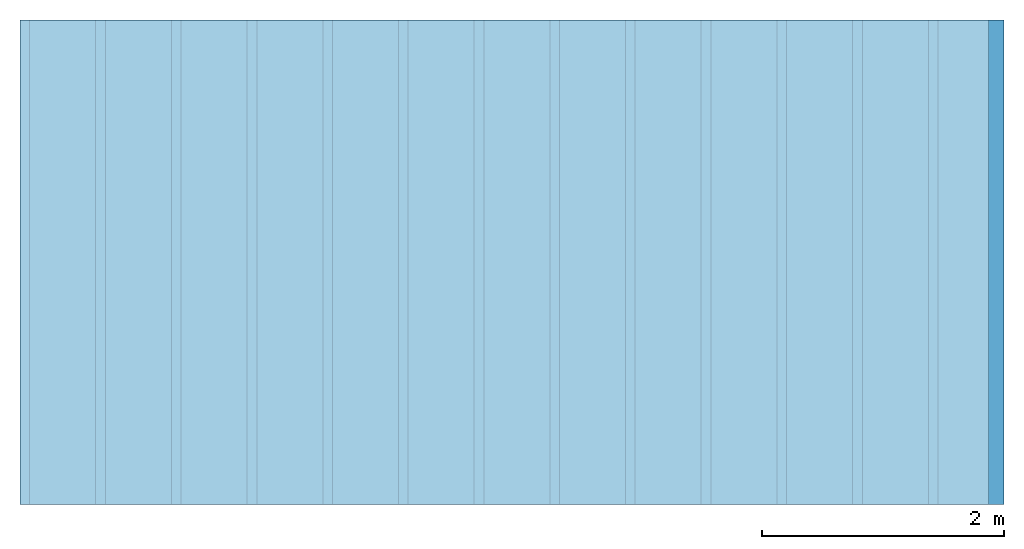
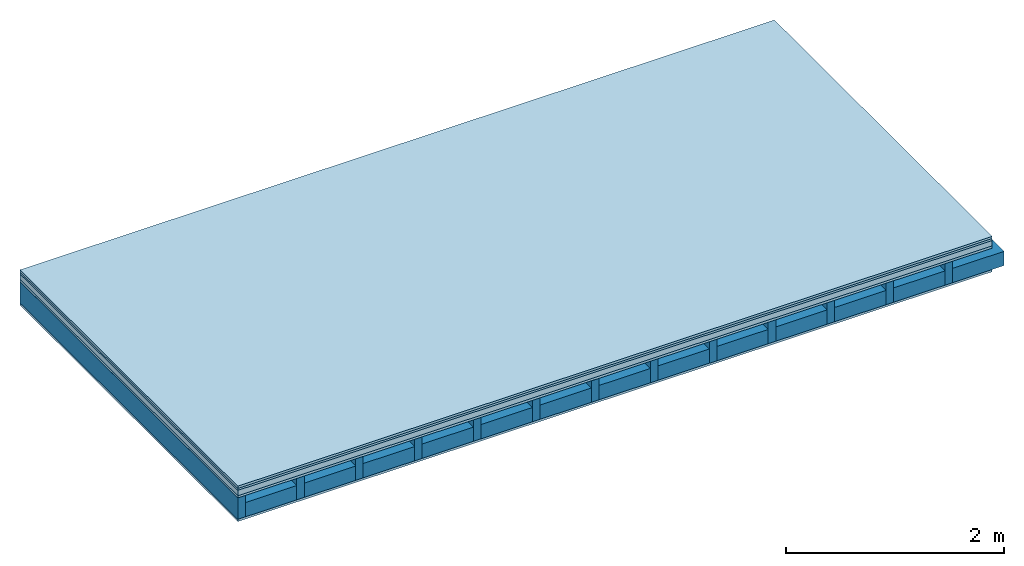
# One storey: 5 plates, 2 members, 1 element without a shape of its own.
"""IFC4 building model written with IfcOpenShell, lengths in metres."""

from ifc_helpers import new_model, si_unit, derived_unit, direction, frame, frame_2d, origin, origin_with_axes, place, context, project, spatial, rectangle, extrude, material, layer, layer_set, type_object, element, aggregate, save


model = new_model("IFC4")

# Units and contexts
plan_context = context("Plan", 3, precision=1e-05, world=origin(), true_north=direction((0.0, 1.0)))
model_context = context("Model", 3, precision=1e-05, world=origin(), true_north=direction((0.0, 1.0)))
ifc_project = project(units=[si_unit("LENGTHUNIT", "METRE"), derived_unit("SOUNDPRESSUREUNIT", [(si_unit("PRESSUREUNIT", "PASCAL", prefix="MICRO"), 0)]), si_unit("ENERGYUNIT", "JOULE", prefix="MEGA"), si_unit("MASSUNIT", "GRAM", prefix="KILO"), derived_unit("THERMALTRANSMITTANCEUNIT", [(si_unit("POWERUNIT", "WATT"), 1), (si_unit("AREAUNIT", "SQUARE_METRE"), -1), (si_unit("THERMODYNAMICTEMPERATUREUNIT", "KELVIN"), -1)]), derived_unit("AREADENSITYUNIT", [(si_unit("MASSUNIT", "GRAM", prefix="KILO"), 1), (si_unit("AREAUNIT", "SQUARE_METRE"), -1)]), derived_unit("USERDEFINED", [(si_unit("ENERGYUNIT", "JOULE", prefix="MEGA"), 1), (si_unit("AREAUNIT", "SQUARE_METRE"), -1)])], contexts=[plan_context, model_context])

# Site, building, storey
site = spatial("IfcSite", under=ifc_project)
building_placement = place(None, origin())
building = spatial("IfcBuilding", under=site, at=building_placement)
storey_placement = place(building_placement, origin())
storey = spatial("IfcBuildingStorey", under=building, at=storey_placement)

# Slab, members, plates
ifc_material_1 = material(Name="Floor heating system Therm38 longitudinal", Category="03.007")
ifc_layer_1 = layer(ifc_material_1, 0.025, Name="On-material")
ifc_material_2 = material(Category="10.009")
ifc_layer_2 = layer(ifc_material_2, 0.022, Name="Impact sound insulation")
ifc_material_3 = material(Category="03.011")
ifc_layer_3 = layer(ifc_material_3, 0.06, Name="on Supporting structure")
ifc_material_4 = material(Category="07.001")
ifc_layer_4 = layer(ifc_material_4, 0.025, Name="Sub-floor")
ifc_material_5 = material(Name="Rigid, of the art")
ifc_layer_5 = layer(ifc_material_5, 0.0, Name="Bond")
ifc_layer_6 = layer(None, 0.24, Name="Supporting structure")
ifc_layer_7 = layer(ifc_material_5, 0.0, Name="Bond")
ifc_layer_8 = layer(ifc_material_4, 0.025, Name="Lower layer 1")
ifc_layer_set = layer_set([ifc_layer_1, ifc_layer_2, ifc_layer_3, ifc_layer_4, ifc_layer_5, ifc_layer_6, ifc_layer_7, ifc_layer_8])
slab_type = type_object("IfcSlabType", Name="A0441", PredefinedType="NOTDEFINED", material=ifc_layer_set)
slab_placement = place(None, frame((0.0, 0.0, 0.0), z_axis=(0.0, 0.0, -1.0), x_axis=(1.0, 0.0, 0.0)))
slab = element("IfcSlab", 1, at=slab_placement, inside=storey, type_object=slab_type, material=ifc_layer_set, Name="Slab #1")
ifc_material_6 = material()
member_1_placement = place(slab_placement, origin())
member_1 = element("IfcMember", 2, at=member_1_placement, material=ifc_material_6, Name="Supporting structure", context=plan_context, shape_type="SweptSolid", body=[
    extrude(rectangle(XDim=0.08, YDim=0.24, at=frame_2d((0.04, 0.12), x_axis=(1.0, 0.0))), frame((0.0, 4.0, 0.132), z_axis=(0.0, -1.0, 0.0), x_axis=(1.0, 0.0, 0.0)), (0.0, 0.0, 1.0), 4.0),
    extrude(rectangle(XDim=0.08, YDim=0.24, at=frame_2d((0.04, 0.12), x_axis=(1.0, 0.0))), frame((0.625, 4.0, 0.132), z_axis=(0.0, -1.0, 0.0), x_axis=(1.0, 0.0, 0.0)), (0.0, 0.0, 1.0), 4.0),
    extrude(rectangle(XDim=0.08, YDim=0.24, at=frame_2d((0.04, 0.12), x_axis=(1.0, 0.0))), frame((1.25, 4.0, 0.132), z_axis=(0.0, -1.0, 0.0), x_axis=(1.0, 0.0, 0.0)), (0.0, 0.0, 1.0), 4.0),
    extrude(rectangle(XDim=0.08, YDim=0.24, at=frame_2d((0.04, 0.12), x_axis=(1.0, 0.0))), frame((1.875, 4.0, 0.132), z_axis=(0.0, -1.0, 0.0), x_axis=(1.0, 0.0, 0.0)), (0.0, 0.0, 1.0), 4.0),
    extrude(rectangle(XDim=0.08, YDim=0.24, at=frame_2d((0.04, 0.12), x_axis=(1.0, 0.0))), frame((2.5, 4.0, 0.132), z_axis=(0.0, -1.0, 0.0), x_axis=(1.0, 0.0, 0.0)), (0.0, 0.0, 1.0), 4.0),
    extrude(rectangle(XDim=0.08, YDim=0.24, at=frame_2d((0.04, 0.12), x_axis=(1.0, 0.0))), frame((3.125, 4.0, 0.132), z_axis=(0.0, -1.0, 0.0), x_axis=(1.0, 0.0, 0.0)), (0.0, 0.0, 1.0), 4.0),
    extrude(rectangle(XDim=0.08, YDim=0.24, at=frame_2d((0.04, 0.12), x_axis=(1.0, 0.0))), frame((3.75, 4.0, 0.132), z_axis=(0.0, -1.0, 0.0), x_axis=(1.0, 0.0, 0.0)), (0.0, 0.0, 1.0), 4.0),
    extrude(rectangle(XDim=0.08, YDim=0.24, at=frame_2d((0.04, 0.12), x_axis=(1.0, 0.0))), frame((4.375, 4.0, 0.132), z_axis=(0.0, -1.0, 0.0), x_axis=(1.0, 0.0, 0.0)), (0.0, 0.0, 1.0), 4.0),
    extrude(rectangle(XDim=0.08, YDim=0.24, at=frame_2d((0.04, 0.12), x_axis=(1.0, 0.0))), frame((5.0, 4.0, 0.132), z_axis=(0.0, -1.0, 0.0), x_axis=(1.0, 0.0, 0.0)), (0.0, 0.0, 1.0), 4.0),
    extrude(rectangle(XDim=0.08, YDim=0.24, at=frame_2d((0.04, 0.12), x_axis=(1.0, 0.0))), frame((5.625, 4.0, 0.132), z_axis=(0.0, -1.0, 0.0), x_axis=(1.0, 0.0, 0.0)), (0.0, 0.0, 1.0), 4.0),
    extrude(rectangle(XDim=0.08, YDim=0.24, at=frame_2d((0.04, 0.12), x_axis=(1.0, 0.0))), frame((6.25, 4.0, 0.132), z_axis=(0.0, -1.0, 0.0), x_axis=(1.0, 0.0, 0.0)), (0.0, 0.0, 1.0), 4.0),
    extrude(rectangle(XDim=0.08, YDim=0.24, at=frame_2d((0.04, 0.12), x_axis=(1.0, 0.0))), frame((6.875, 4.0, 0.132), z_axis=(0.0, -1.0, 0.0), x_axis=(1.0, 0.0, 0.0)), (0.0, 0.0, 1.0), 4.0),
    extrude(rectangle(XDim=0.08, YDim=0.24, at=frame_2d((0.04, 0.12), x_axis=(1.0, 0.0))), frame((7.5, 4.0, 0.132), z_axis=(0.0, -1.0, 0.0), x_axis=(1.0, 0.0, 0.0)), (0.0, 0.0, 1.0), 4.0),
])
ifc_material_7 = material()
member_2_placement = place(slab_placement, origin())
member_2 = element("IfcMember", 3, at=member_2_placement, material=ifc_material_7, Name="Cavity", context=plan_context, shape_type="SweptSolid", body=[
    extrude(rectangle(XDim=0.545, YDim=0.16, at=frame_2d((0.2725, 0.08), x_axis=(1.0, 0.0))), frame((0.08, 4.0, 0.212), z_axis=(0.0, -1.0, 0.0), x_axis=(1.0, 0.0, 0.0)), (0.0, 0.0, 1.0), 4.0),
    extrude(rectangle(XDim=0.545, YDim=0.16, at=frame_2d((0.2725, 0.08), x_axis=(1.0, 0.0))), frame((0.705, 4.0, 0.212), z_axis=(0.0, -1.0, 0.0), x_axis=(1.0, 0.0, 0.0)), (0.0, 0.0, 1.0), 4.0),
    extrude(rectangle(XDim=0.545, YDim=0.16, at=frame_2d((0.2725, 0.08), x_axis=(1.0, 0.0))), frame((1.33, 4.0, 0.212), z_axis=(0.0, -1.0, 0.0), x_axis=(1.0, 0.0, 0.0)), (0.0, 0.0, 1.0), 4.0),
    extrude(rectangle(XDim=0.545, YDim=0.16, at=frame_2d((0.2725, 0.08), x_axis=(1.0, 0.0))), frame((1.955, 4.0, 0.212), z_axis=(0.0, -1.0, 0.0), x_axis=(1.0, 0.0, 0.0)), (0.0, 0.0, 1.0), 4.0),
    extrude(rectangle(XDim=0.545, YDim=0.16, at=frame_2d((0.2725, 0.08), x_axis=(1.0, 0.0))), frame((2.58, 4.0, 0.212), z_axis=(0.0, -1.0, 0.0), x_axis=(1.0, 0.0, 0.0)), (0.0, 0.0, 1.0), 4.0),
    extrude(rectangle(XDim=0.545, YDim=0.16, at=frame_2d((0.2725, 0.08), x_axis=(1.0, 0.0))), frame((3.205, 4.0, 0.212), z_axis=(0.0, -1.0, 0.0), x_axis=(1.0, 0.0, 0.0)), (0.0, 0.0, 1.0), 4.0),
    extrude(rectangle(XDim=0.545, YDim=0.16, at=frame_2d((0.2725, 0.08), x_axis=(1.0, 0.0))), frame((3.83, 4.0, 0.212), z_axis=(0.0, -1.0, 0.0), x_axis=(1.0, 0.0, 0.0)), (0.0, 0.0, 1.0), 4.0),
    extrude(rectangle(XDim=0.545, YDim=0.16, at=frame_2d((0.2725, 0.08), x_axis=(1.0, 0.0))), frame((4.455, 4.0, 0.212), z_axis=(0.0, -1.0, 0.0), x_axis=(1.0, 0.0, 0.0)), (0.0, 0.0, 1.0), 4.0),
    extrude(rectangle(XDim=0.545, YDim=0.16, at=frame_2d((0.2725, 0.08), x_axis=(1.0, 0.0))), frame((5.08, 4.0, 0.212), z_axis=(0.0, -1.0, 0.0), x_axis=(1.0, 0.0, 0.0)), (0.0, 0.0, 1.0), 4.0),
    extrude(rectangle(XDim=0.545, YDim=0.16, at=frame_2d((0.2725, 0.08), x_axis=(1.0, 0.0))), frame((5.705, 4.0, 0.212), z_axis=(0.0, -1.0, 0.0), x_axis=(1.0, 0.0, 0.0)), (0.0, 0.0, 1.0), 4.0),
    extrude(rectangle(XDim=0.545, YDim=0.16, at=frame_2d((0.2725, 0.08), x_axis=(1.0, 0.0))), frame((6.33, 4.0, 0.212), z_axis=(0.0, -1.0, 0.0), x_axis=(1.0, 0.0, 0.0)), (0.0, 0.0, 1.0), 4.0),
    extrude(rectangle(XDim=0.545, YDim=0.16, at=frame_2d((0.2725, 0.08), x_axis=(1.0, 0.0))), frame((6.955, 4.0, 0.212), z_axis=(0.0, -1.0, 0.0), x_axis=(1.0, 0.0, 0.0)), (0.0, 0.0, 1.0), 4.0),
    extrude(rectangle(XDim=0.545, YDim=0.16, at=frame_2d((0.2725, 0.08), x_axis=(1.0, 0.0))), frame((7.58, 4.0, 0.212), z_axis=(0.0, -1.0, 0.0), x_axis=(1.0, 0.0, 0.0)), (0.0, 0.0, 1.0), 4.0),
])
plate_1_placement = place(slab_placement, origin())
plate_1 = element("IfcPlate", 4, at=plate_1_placement, material=ifc_material_1, Name="On-material", context=plan_context, shape_type="SweptSolid", body=[
    extrude(rectangle(XDim=8.0, YDim=4.0, at=frame_2d((4.0, 2.0), x_axis=(1.0, 0.0))), origin_with_axes(), (0.0, 0.0, 1.0), 0.025),
])
plate_2_placement = place(slab_placement, origin())
plate_2 = element("IfcPlate", 5, at=plate_2_placement, material=ifc_material_2, Name="Impact sound insulation", context=plan_context, shape_type="SweptSolid", body=[
    extrude(rectangle(XDim=8.0, YDim=4.0, at=frame_2d((4.0, 2.0), x_axis=(1.0, 0.0))), frame((0.0, 0.0, 0.025), z_axis=(0.0, 0.0, 1.0), x_axis=(1.0, 0.0, 0.0)), (0.0, 0.0, 1.0), 0.022),
])
plate_3_placement = place(slab_placement, origin())
plate_3 = element("IfcPlate", 6, at=plate_3_placement, material=ifc_material_3, Name="on Supporting structure", context=plan_context, shape_type="SweptSolid", body=[
    extrude(rectangle(XDim=8.0, YDim=4.0, at=frame_2d((4.0, 2.0), x_axis=(1.0, 0.0))), frame((0.0, 0.0, 0.047), z_axis=(0.0, 0.0, 1.0), x_axis=(1.0, 0.0, 0.0)), (0.0, 0.0, 1.0), 0.06),
])
plate_4_placement = place(slab_placement, origin())
plate_4 = element("IfcPlate", 7, at=plate_4_placement, material=ifc_material_4, Name="Sub-floor", context=plan_context, shape_type="SweptSolid", body=[
    extrude(rectangle(XDim=8.0, YDim=4.0, at=frame_2d((4.0, 2.0), x_axis=(1.0, 0.0))), frame((0.0, 0.0, 0.107), z_axis=(0.0, 0.0, 1.0), x_axis=(1.0, 0.0, 0.0)), (0.0, 0.0, 1.0), 0.025),
])
plate_5_placement = place(slab_placement, origin())
plate_5 = element("IfcPlate", 8, at=plate_5_placement, material=ifc_material_4, Name="Lower layer 1", context=plan_context, shape_type="SweptSolid", body=[
    extrude(rectangle(XDim=8.0, YDim=4.0, at=frame_2d((4.0, 2.0), x_axis=(1.0, 0.0))), frame((0.0, 0.0, 0.372), z_axis=(0.0, 0.0, 1.0), x_axis=(1.0, 0.0, 0.0)), (0.0, 0.0, 1.0), 0.025),
])
aggregate(slab, [plate_1, plate_2, plate_3, plate_4, member_1, member_2, plate_5])

save(model, "model.ifc")
